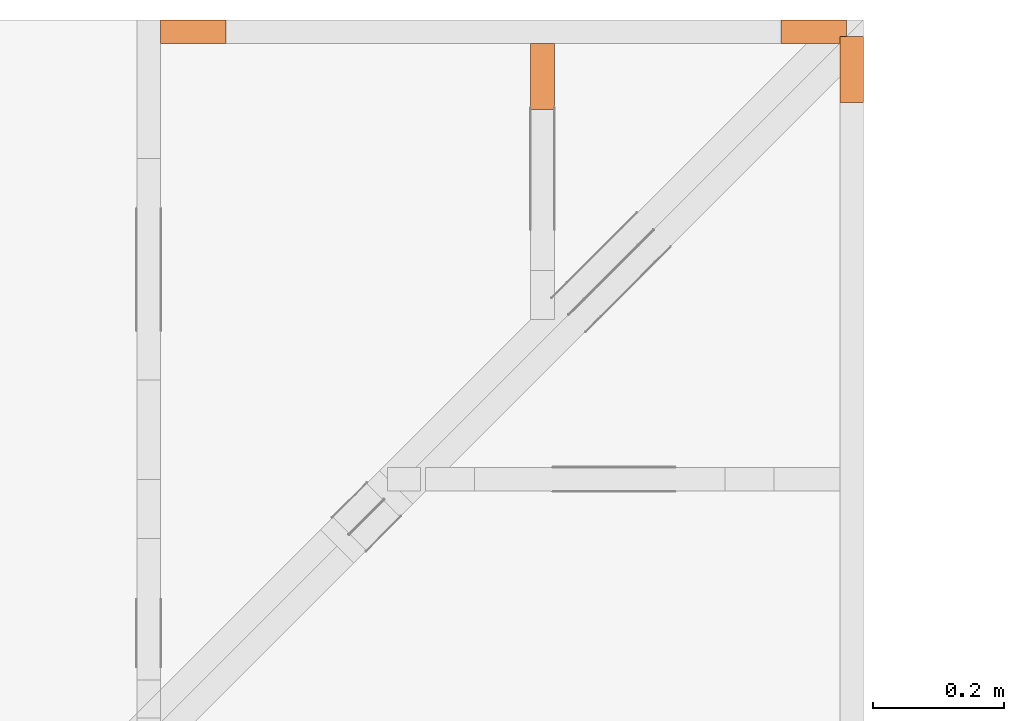
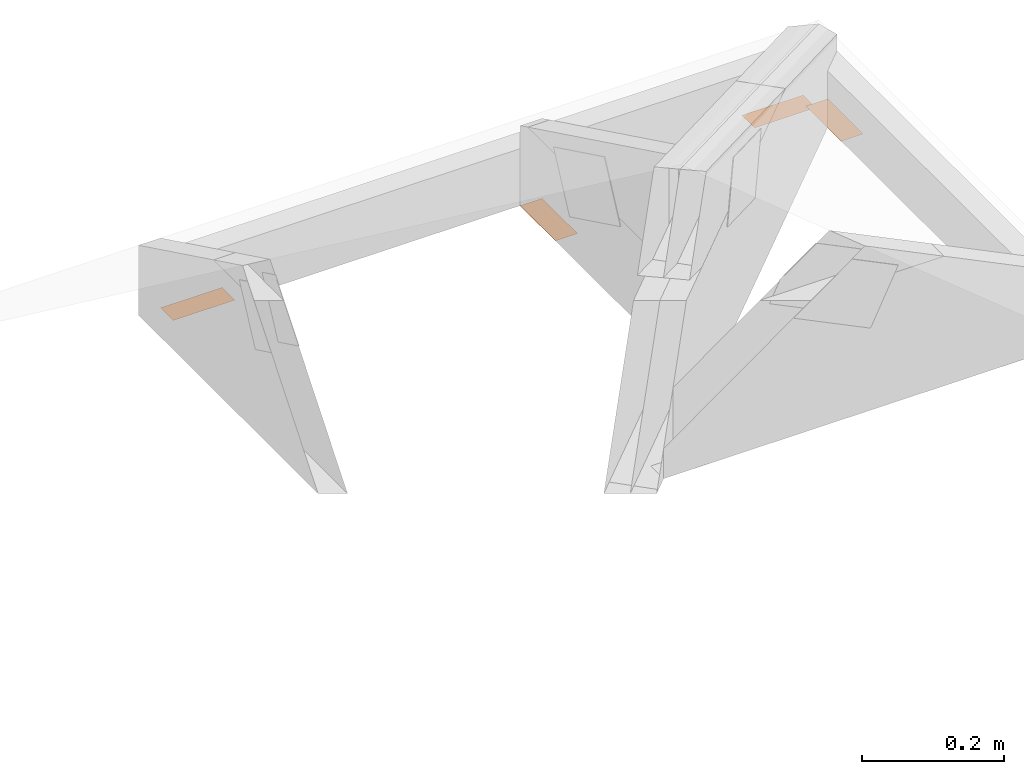
# One storey, part 147 of 159: 4 proxies, 3 elements without a shape of their own.
"""IFC2X3 building model written with IfcOpenShell, lengths in millimetres."""

from ifc_helpers import new_model, si_unit, frame, origin, origin_with_axes, origin_2d, place, context, project, spatial, open_shell, surface_model, element, aggregate, save


model = new_model("IFC2X3")

# Units and contexts
model_context = context("Model", 3, precision=1e-05, world=origin())
plan_context = context("Plan", 2, precision=1e-05, world=origin_2d())
ifc_project = project(units=[si_unit("LENGTHUNIT", "METRE", prefix="MILLI"), si_unit("AREAUNIT", "SQUARE_METRE"), si_unit("VOLUMEUNIT", "CUBIC_METRE"), si_unit("SOLIDANGLEUNIT", "STERADIAN"), si_unit("PLANEANGLEUNIT", "RADIAN"), si_unit("MASSUNIT", "GRAM"), si_unit("TIMEUNIT", "SECOND"), si_unit("THERMODYNAMICTEMPERATUREUNIT", "DEGREE_CELSIUS"), si_unit("LUMINOUSINTENSITYUNIT", "LUMEN")], contexts=[model_context, plan_context])

# Site, building, storey
site_placement = place(None, origin_with_axes())
site = spatial("IfcSite", under=ifc_project, at=site_placement, CompositionType="ELEMENT")
building_placement = place(site_placement, origin_with_axes())
building = spatial("IfcBuilding", under=site, at=building_placement, Name="Plan 1", CompositionType="ELEMENT")
storey_placement = place(building_placement, origin_with_axes())
storey = spatial("IfcBuildingStorey", under=building, at=storey_placement, Name="Etasje 1", CompositionType="ELEMENT", Elevation=0.0)

# Assembly, proxy
assembly_1_placement = place(storey_placement, frame((19200.01266310149, 12017.999978540158, 0.0), z_axis=(1.0, -6.123031769111886e-17, 6.123031769111886e-17), x_axis=(6.123031769111886e-17, 1.0, 0.0)))
assembly_1 = element("IfcElementAssembly", 1, at=assembly_1_placement, inside=storey, Name="uu5 (1)", AssemblyPlace="FACTORY", PredefinedType="TRUSS")
proxy_1_placement = place(assembly_1_placement, frame((1756.5441558772782, -1.2246063538223773e-14, 0.0), z_axis=(-1.2246063538223773e-16, 1.0, 0.0), x_axis=(1.0, 1.2246063538223773e-16, 0.0)))
proxy_1 = element("IfcBuildingElementProxy", 2, at=proxy_1_placement, Name="2", context=model_context, shape_type="SurfaceModel", body=[
    surface_model("IfcFaceBasedSurfaceModel", [(0.0, 0.0, 0.0), (100.0, 0.0, 0.0), (100.0, 36.0, 0.0), (0.0, 36.0, 0.0)], [open_shell([[[0, 1, 2, 3]]], orient=[[False]])]),
])
aggregate(assembly_1, [proxy_1])

# Assembly, proxies
assembly_2_placement = place(storey_placement, frame((18129.02226140476, 13863.999978546979, 2.204291436880279e-15), z_axis=(0.0, -1.0, 6.123031769111886e-17), x_axis=(1.0, 0.0, 0.0)))
assembly_2 = element("IfcElementAssembly", 3, at=assembly_2_placement, inside=storey, Name="uu7 (1)", AssemblyPlace="FACTORY", PredefinedType="TRUSS")
proxy_2_placement = place(assembly_2_placement, frame((945.5345575463725, -1.2246063538223773e-14, 0.0), z_axis=(-1.2246063538223773e-16, 1.0, 0.0), x_axis=(1.0, 1.2246063538223773e-16, 0.0)))
proxy_2 = element("IfcBuildingElementProxy", 4, at=proxy_2_placement, Name="2", context=model_context, shape_type="SurfaceModel", body=[
    surface_model("IfcFaceBasedSurfaceModel", [(-1.1859810911118984e-09, 0.0, 0.0), (100.0, -3.296008799225092e-09, 0.0), (100.00000000118598, 36.0, -2.524354896707238e-29), (0.0, 36.00000000329601, 0.0)], [open_shell([[[0, 1, 2, 3]]], orient=[[False]])]),
])
proxy_3_placement = place(assembly_2_placement, frame((0.0, 0.0, 0.0), z_axis=(0.0, 1.0, 0.0), x_axis=(1.0, 0.0, 0.0)))
proxy_3 = element("IfcBuildingElementProxy", 5, at=proxy_3_placement, Name="1", context=model_context, shape_type="SurfaceModel", body=[
    surface_model("IfcFaceBasedSurfaceModel", [(-1.1859810911118984e-09, 0.0, 0.0), (100.0, -3.296008799225092e-09, 0.0), (100.00000000118598, 36.0, 0.0), (0.0, 36.00000000329601, 0.0)], [open_shell([[[0, 1, 2, 3]]], orient=[[False]])]),
])
aggregate(assembly_2, [proxy_2, proxy_3])

# Assembly, proxy
assembly_3_placement = place(storey_placement, frame((18693.022261405276, 13863.999978522186, 1.1021457184401395e-15), z_axis=(-1.0, -5.322035539589813e-11, 6.123031769111886e-17), x_axis=(5.322035539589813e-11, -1.0, 0.0)))
assembly_3 = element("IfcElementAssembly", 6, at=assembly_3_placement, inside=storey, Name="S43 (1)", AssemblyPlace="FACTORY", PredefinedType="TRUSS")
proxy_4_placement = place(assembly_3_placement, frame((0.0, 0.0, 0.0), z_axis=(0.0, 1.0, 0.0), x_axis=(1.0, 0.0, 0.0)))
proxy_4 = element("IfcBuildingElementProxy", 7, at=proxy_4_placement, Name="1", context=model_context, shape_type="SurfaceModel", body=[
    surface_model("IfcFaceBasedSurfaceModel", [(0.0, 0.0, 0.0), (100.0, 0.0, 0.0), (100.0, 36.0, 0.0), (0.0, 36.0, 0.0)], [open_shell([[[0, 1, 2, 3]]], orient=[[False]])]),
])
aggregate(assembly_3, [proxy_4])

save(model, "model.ifc")
